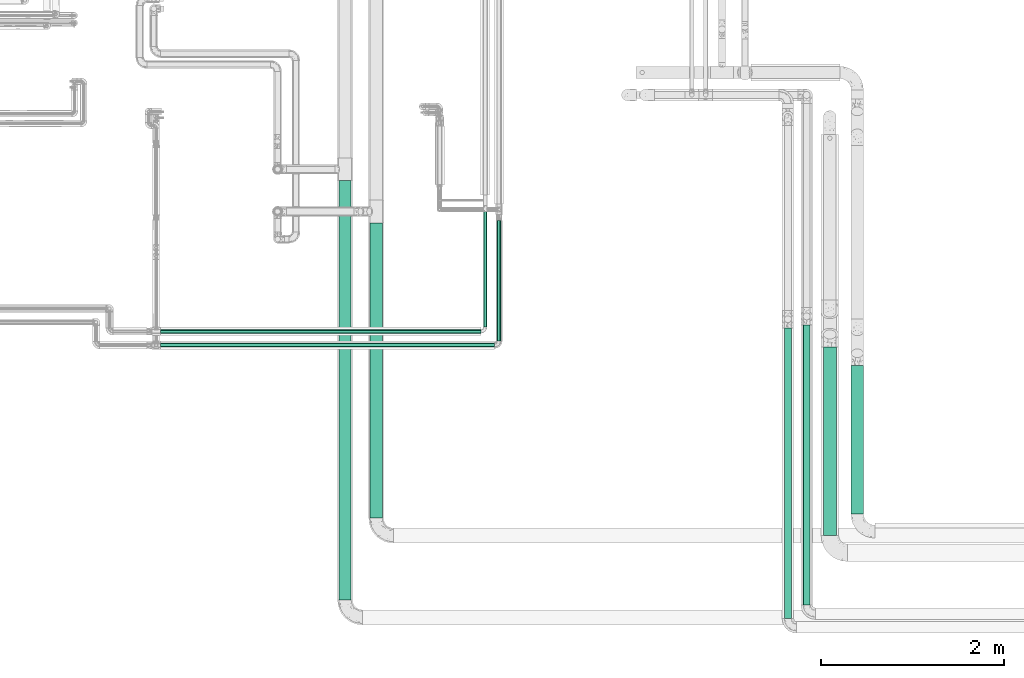
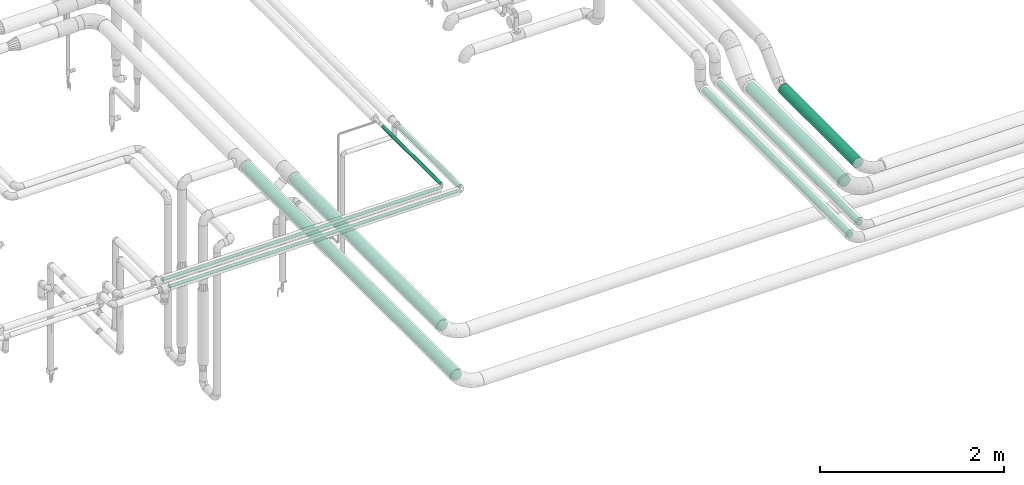
# One storey, part 521 of 827: 10 flow segments.
"""IFC2X3 building model written with IfcOpenShell, lengths in millimetres."""

from ifc_helpers import new_model, entity, si_unit, converted_unit, derived_unit, direction, frame, origin, origin_2d_with_axis, place, context, subcontext, project, spatial, circle, extrude, type_object, element, save


model = new_model("IFC2X3")

# Units and contexts
model_context = context("Model", 3, precision=0.01, world=origin(), true_north=direction((6.12303176911189e-17, 1.0)))
body_context = subcontext(model_context, "Body", "Model", "MODEL_VIEW")
ifc_project = project(units=[si_unit("LENGTHUNIT", "METRE", prefix="MILLI"), si_unit("AREAUNIT", "SQUARE_METRE"), si_unit("VOLUMEUNIT", "CUBIC_METRE"), converted_unit("PLANEANGLEUNIT", "DEGREE", entity("IfcRatioMeasure", 0.0174532925199433), si_unit("PLANEANGLEUNIT", "RADIAN"), dimensions=[0, 0, 0, 0, 0, 0, 0]), si_unit("MASSUNIT", "GRAM", prefix="KILO"), derived_unit("MASSDENSITYUNIT", [(si_unit("MASSUNIT", "GRAM", prefix="KILO"), 1), (si_unit("LENGTHUNIT", "METRE"), -3)]), derived_unit("MOMENTOFINERTIAUNIT", [(si_unit("LENGTHUNIT", "METRE"), 4)]), si_unit("TIMEUNIT", "SECOND"), si_unit("FREQUENCYUNIT", "HERTZ"), si_unit("THERMODYNAMICTEMPERATUREUNIT", "DEGREE_CELSIUS"), derived_unit("THERMALTRANSMITTANCEUNIT", [(si_unit("MASSUNIT", "GRAM", prefix="KILO"), 1), (si_unit("THERMODYNAMICTEMPERATUREUNIT", "KELVIN"), -1), (si_unit("TIMEUNIT", "SECOND"), -3)]), derived_unit("VOLUMETRICFLOWRATEUNIT", [(si_unit("LENGTHUNIT", "METRE"), 3), (si_unit("TIMEUNIT", "SECOND"), -1)]), derived_unit("MASSFLOWRATEUNIT", [(si_unit("MASSUNIT", "GRAM", prefix="KILO"), 1), (si_unit("TIMEUNIT", "SECOND"), -1)]), derived_unit("ROTATIONALFREQUENCYUNIT", [(si_unit("TIMEUNIT", "SECOND"), -1)]), si_unit("ELECTRICCURRENTUNIT", "AMPERE"), si_unit("ELECTRICVOLTAGEUNIT", "VOLT"), si_unit("POWERUNIT", "WATT"), si_unit("FORCEUNIT", "NEWTON", prefix="KILO"), si_unit("ILLUMINANCEUNIT", "LUX"), si_unit("LUMINOUSFLUXUNIT", "LUMEN"), si_unit("LUMINOUSINTENSITYUNIT", "CANDELA"), derived_unit("USERDEFINED", [(si_unit("MASSUNIT", "GRAM", prefix="KILO"), -1), (si_unit("LENGTHUNIT", "METRE"), -2), (si_unit("TIMEUNIT", "SECOND"), 3), (si_unit("LUMINOUSFLUXUNIT", "LUMEN"), 1)]), derived_unit("LINEARVELOCITYUNIT", [(si_unit("LENGTHUNIT", "METRE"), 1), (si_unit("TIMEUNIT", "SECOND"), -1)]), si_unit("PRESSUREUNIT", "PASCAL"), derived_unit("USERDEFINED", [(si_unit("LENGTHUNIT", "METRE"), -2), (si_unit("MASSUNIT", "GRAM", prefix="KILO"), 1), (si_unit("TIMEUNIT", "SECOND"), -2)]), derived_unit("LINEARFORCEUNIT", [(si_unit("MASSUNIT", "GRAM", prefix="KILO"), 1), (si_unit("LENGTHUNIT", "METRE"), 1), (si_unit("TIMEUNIT", "SECOND"), -2), (si_unit("LENGTHUNIT", "METRE"), -1)]), derived_unit("PLANARFORCEUNIT", [(si_unit("MASSUNIT", "GRAM", prefix="KILO"), 1), (si_unit("LENGTHUNIT", "METRE"), 1), (si_unit("TIMEUNIT", "SECOND"), -2), (si_unit("LENGTHUNIT", "METRE"), -2)])], contexts=[model_context])

# Site, building, storey
site_placement = place(None, origin())
site = spatial("IfcSite", under=ifc_project, at=site_placement, CompositionType="ELEMENT")
building_placement = place(site_placement, origin())
building = spatial("IfcBuilding", under=site, at=building_placement, CompositionType="ELEMENT")
storey_placement = place(building_placement, frame((0.0, 0.0, 28200.0)))
storey = spatial("IfcBuildingStorey", under=building, at=storey_placement, Name="08", CompositionType="ELEMENT", Elevation=28200.0)

# Flow segments
pipe_segment_type_1 = type_object("IfcPipeSegmentType", PredefinedType="NOTDEFINED")
flow_segment_1_placement = place(storey_placement, frame((21767.01, 6565.0, 2731.9)))
element("IfcFlowSegment", 1, at=flow_segment_1_placement, inside=storey, type_object=pipe_segment_type_1, context=body_context, shape_type="SweptSolid", body=[
    extrude(circle(Radius=66.5, at=origin_2d_with_axis()), frame((68.1, 0.0, 68.1), z_axis=(0.0, 1.0, 0.0), x_axis=(1.0, 0.0, 0.0)), (0.0, 0.0, 1.0), 4570.64796604332),
])
flow_segment_2_placement = place(storey_placement, frame((22106.66, 7456.2, 2731.91)))
element("IfcFlowSegment", 2, at=flow_segment_2_placement, inside=storey, type_object=pipe_segment_type_1, context=body_context, shape_type="SweptSolid", body=[
    extrude(circle(Radius=66.5, at=origin_2d_with_axis()), frame((68.1, 0.0, 68.1), z_axis=(0.0, 1.0, 0.0), x_axis=(1.0, 0.0, 0.0)), (0.0, 0.0, 1.0), 3219.44443281138),
])
flow_segment_3_placement = place(storey_placement, frame((27351.94, 7500.0, 3031.9)))
element("IfcFlowSegment", 3, at=flow_segment_3_placement, inside=storey, type_object=pipe_segment_type_1, context=body_context, shape_type="SweptSolid", body=[
    extrude(circle(Radius=66.5, at=origin_2d_with_axis()), frame((68.1, 0.0, 68.1), z_axis=(0.0, 1.0, 0.0), x_axis=(1.0, 0.0, 0.0)), (0.0, 0.0, 1.0), 1620.10942162512),
])
pipe_segment_type_2 = type_object("IfcPipeSegmentType", PredefinedType="NOTDEFINED")
flow_segment_4_placement = place(storey_placement, frame((23340.57, 9540.8, 2974.33)))
element("IfcFlowSegment", 4, at=flow_segment_4_placement, inside=storey, type_object=pipe_segment_type_2, context=body_context, shape_type="SweptSolid", body=[
    extrude(circle(Radius=21.15, at=origin_2d_with_axis()), frame((22.75, 0.0, 22.75), z_axis=(0.0, 1.0, -6.92578198128991e-08), x_axis=(1.0, 0.0, 0.0)), (0.0, 0.0, 1.0), 1260.47200031952),
])
flow_segment_5_placement = place(storey_placement, frame((19824.27, 9320.05, 2973.72)))
element("IfcFlowSegment", 5, at=flow_segment_5_placement, inside=storey, type_object=pipe_segment_type_2, context=body_context, shape_type="SweptSolid", body=[
    extrude(circle(Radius=21.15, at=origin_2d_with_axis()), frame((0.0, 22.75, 22.75), z_axis=(1.0, 0.0, 0.0), x_axis=(0.0, 1.0, 0.0)), (0.0, 0.0, 1.0), 3642.11493062338),
])
flow_segment_6_placement = place(storey_placement, frame((19824.27, 9470.05, 2974.41)))
element("IfcFlowSegment", 6, at=flow_segment_6_placement, inside=storey, type_object=pipe_segment_type_2, context=body_context, shape_type="SweptSolid", body=[
    extrude(circle(Radius=21.15, at=origin_2d_with_axis()), frame((3491.04, 22.75, 22.75), z_axis=(-1.0, 0.0, 1.92641960183011e-05), x_axis=(0.0, 1.0, 0.0)), (0.0, 0.0, 1.0), 3491.04340282385),
])
flow_segment_7_placement = place(storey_placement, frame((23491.64, 9390.8, 2973.64)))
element("IfcFlowSegment", 7, at=flow_segment_7_placement, inside=storey, type_object=pipe_segment_type_2, context=body_context, shape_type="SweptSolid", body=[
    extrude(circle(Radius=21.15, at=origin_2d_with_axis()), frame((22.75, 0.0, 22.75), z_axis=(0.0, 0.999999997129731, 7.57663358726185e-05), x_axis=(-1.0, 0.0, 0.0)), (0.0, 0.0, 1.0), 1310.59110257094),
])
flow_segment_8_placement = place(storey_placement, frame((26624.29, 6360.71, 3060.65)))
element("IfcFlowSegment", 8, at=flow_segment_8_placement, inside=storey, type_object=pipe_segment_type_2, context=body_context, shape_type="SweptSolid", body=[
    extrude(circle(Radius=37.75, at=origin_2d_with_axis()), frame((39.35, 0.0, 39.35), z_axis=(0.0, 1.0, 0.0), x_axis=(1.0, 0.0, 0.0)), (0.0, 0.0, 1.0), 3170.00000000002),
])
flow_segment_9_placement = place(storey_placement, frame((26828.29, 6511.57, 3060.65)))
element("IfcFlowSegment", 9, at=flow_segment_9_placement, inside=storey, type_object=pipe_segment_type_2, context=body_context, shape_type="SweptSolid", body=[
    extrude(circle(Radius=37.75, at=origin_2d_with_axis()), frame((39.35, 0.0, 39.35), z_axis=(0.0, 1.0, 0.0), x_axis=(1.0, 0.0, 0.0)), (0.0, 0.0, 1.0), 3050.00000000001),
])
flow_segment_10_placement = place(storey_placement, frame((27048.74, 7270.0, 3028.4)))
element("IfcFlowSegment", 10, at=flow_segment_10_placement, inside=storey, type_object=pipe_segment_type_2, context=body_context, shape_type="SweptSolid", body=[
    extrude(circle(Radius=70.0, at=origin_2d_with_axis()), frame((71.6, 0.0, 71.6), z_axis=(0.0, 1.0, 0.0), x_axis=(1.0, 0.0, 0.0)), (0.0, 0.0, 1.0), 2055.10942162512),
])

save(model, "model.ifc")
